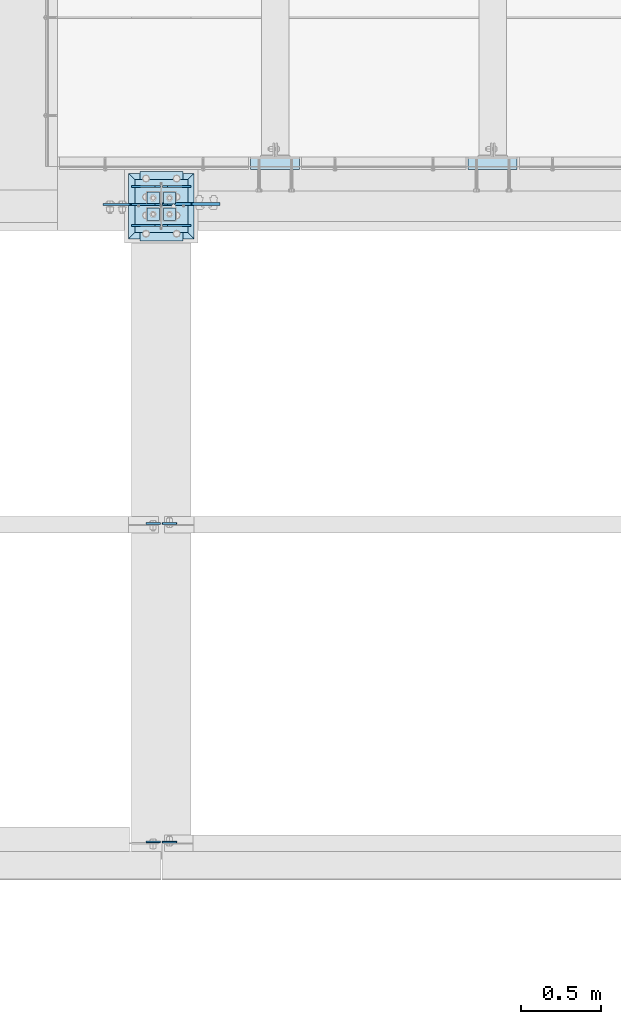
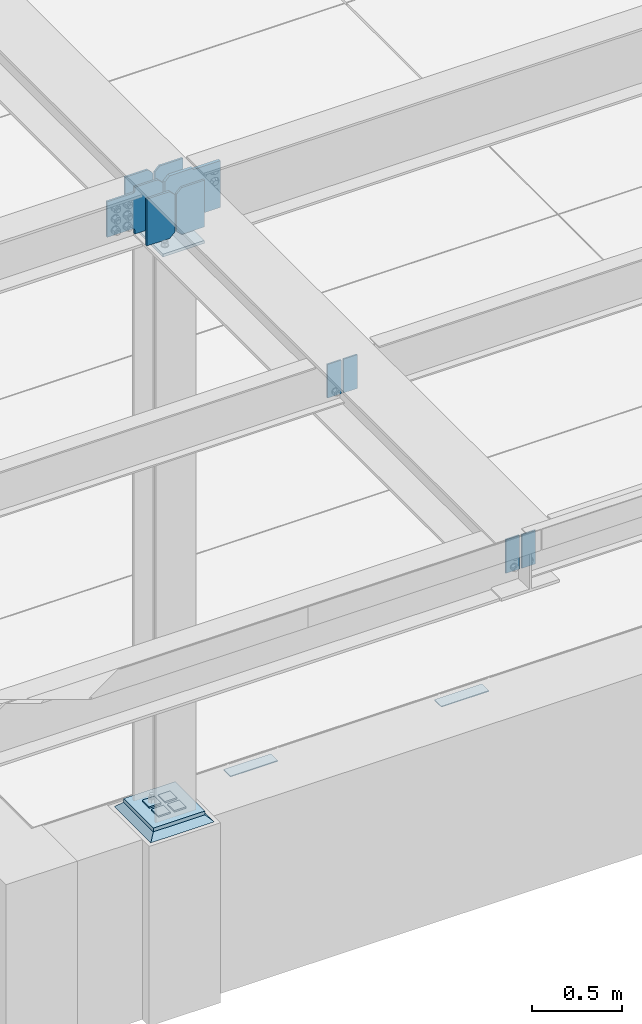
# One storey, part 3013 of 3843: 19 plates, 6 elements without a shape of their own.
"""IFC2X3 building model written with IfcOpenShell, lengths in millimetres."""

import ifcopenshell
import ifcopenshell.guid

model = None  # the IFC model being written
_history = None  # IfcOwnerHistory: only IFC2X3 demands one
_inside = {}  # id of a spatial element -> (the spatial element, [elements in it])
_under = {}  # id of a project, library or spatial element -> (it, [spatial elements below it])
_declared = {}  # id of a project -> (the project, [libraries it declares])
_typed = {}  # id of a type object -> (the type object, [elements of that type])
_made_of = {}  # id of a material, layer set ... -> (it, [elements and type objects made of it])


def new_model(schema):
    """Start an empty IFC model of exactly this schema.

    Asked for "IFC4X3", IfcOpenShell would pick the latest addendum, in which some entities
    have other attributes; the version numbers below select the first issue.
    IFC2X3 requires an IfcOwnerHistory on every rooted entity: one is made here for all.
    """
    global model, _history
    if schema == "IFC4X3":
        model = ifcopenshell.file(schema_version=(4, 3, 0, 0))
    else:
        model = ifcopenshell.file(schema=schema)
    _inside.clear()
    _under.clear()
    _declared.clear()
    _typed.clear()
    _made_of.clear()
    _history = None
    if model.schema == "IFC2X3":
        org = make("IfcOrganization", Name="unknown")
        user = make(
            "IfcPersonAndOrganization",
            ThePerson=make("IfcPerson", FamilyName="unknown"),
            TheOrganization=org,
        )
        app = make(
            "IfcApplication",
            ApplicationDeveloper=org,
            Version="unknown",
            ApplicationFullName="unknown",
            ApplicationIdentifier="unknown",
        )
        _history = make(
            "IfcOwnerHistory",
            OwningUser=user,
            OwningApplication=app,
            ChangeAction="ADDED",
            CreationDate=0,
        )
    return model


def make(cls, **values):
    """One entity of the class cls with the attributes given. An attribute that is None is left unset."""
    return model.create_entity(
        cls, **{name: value for name, value in values.items() if value is not None}
    )


def rooted(cls, **values):
    """An entity with a GlobalId (a new one), such as an element, a storey or a relation."""
    return make(cls, GlobalId=ifcopenshell.guid.new(), OwnerHistory=_history, **values)


def si_unit(unit_type, name, prefix=None):
    """IfcSIUnit, for example si_unit("LENGTHUNIT", "METRE", prefix="MILLI")."""
    return make("IfcSIUnit", UnitType=unit_type, Prefix=prefix, Name=name)


def assignment(units):
    """IfcUnitAssignment: the units of a project."""
    return None if units is None else make("IfcUnitAssignment", Units=units)


def point(xyz):
    """IfcCartesianPoint."""
    return None if xyz is None else make("IfcCartesianPoint", Coordinates=xyz)


def direction(xyz):
    """IfcDirection."""
    return None if xyz is None else make("IfcDirection", DirectionRatios=xyz)


def frame(location, z_axis=None, x_axis=None):
    """IfcAxis2Placement3D, a coordinate frame: its origin and axes. An axis left out is left unset."""
    return make(
        "IfcAxis2Placement3D",
        Location=point(location),
        Axis=direction(z_axis),
        RefDirection=direction(x_axis),
    )


def origin_with_axes():
    """The frame at (0, 0, 0) with the z axis (0, 0, 1) and the x axis (1, 0, 0) written out."""
    return frame((0.0, 0.0, 0.0), z_axis=(0.0, 0.0, 1.0), x_axis=(1.0, 0.0, 0.0))


def place(relative_to, where):
    """IfcLocalPlacement: puts the frame where relative to a parent placement (None: the world)."""
    return make(
        "IfcLocalPlacement", PlacementRelTo=relative_to, RelativePlacement=where
    )


def context(
    kind, dimensions, precision=None, world=None, true_north=None, identifier=None
):
    """IfcGeometricRepresentationContext, for example the 3D "Model" context."""
    return make(
        "IfcGeometricRepresentationContext",
        ContextIdentifier=identifier,
        ContextType=kind,
        CoordinateSpaceDimension=dimensions,
        Precision=precision,
        WorldCoordinateSystem=world,
        TrueNorth=true_north,
    )


def subcontext(parent, identifier, kind, view, scale=None):
    """IfcGeometricRepresentationSubContext, for example "Body" below "Model"."""
    return make(
        "IfcGeometricRepresentationSubContext",
        ContextIdentifier=identifier,
        ContextType=kind,
        ParentContext=parent,
        TargetScale=scale,
        TargetView=view,
    )


def project(units=None, contexts=None):
    """IfcProject with its units and contexts."""
    return rooted(
        "IfcProject",
        Name="project",
        RepresentationContexts=contexts,
        UnitsInContext=assignment(units),
    )


def spatial(cls, under=None, at=None, **own):
    """A site, building, storey or space (cls), placed at a placement, below another one or the project."""
    s = rooted(cls, ObjectPlacement=at, **own)
    if under is not None:
        _under.setdefault(under.id(), (under, []))[1].append(s)
    return s


def faces_of(points, faces, orient=None, outer=None):
    """IfcFace entities. A face is a list of loops; a loop is a list of indices into points, from 0.

    orient and outer hold one flag for each loop. By default every Orientation is true, the
    first loop of a face is its IfcFaceOuterBound and the others are IfcFaceBound.
    """
    made = []
    for i, loops in enumerate(faces):
        bounds = []
        for j, loop in enumerate(loops):
            is_outer = j == 0 if outer is None else outer[i][j]
            bounds.append(
                make(
                    "IfcFaceOuterBound" if is_outer else "IfcFaceBound",
                    Bound=make("IfcPolyLoop", Polygon=[points[k] for k in loop]),
                    Orientation=True if orient is None else orient[i][j],
                )
            )
        made.append(make("IfcFace", Bounds=bounds))
    return made


def faceted_brep(points, faces, orient=None, outer=None, voids=None):
    """IfcFacetedBrep: a solid bounded by flat faces; with voids (closed shells), ...WithVoids."""
    shared = [point(p) for p in points]
    hull = make("IfcClosedShell", CfsFaces=faces_of(shared, faces, orient, outer))
    if voids is None:
        return make("IfcFacetedBrep", Outer=hull)
    return make(
        "IfcFacetedBrepWithVoids",
        Outer=hull,
        Voids=[
            make(cls, CfsFaces=faces_of(shared, fs, o, b)) for cls, fs, o, b in voids
        ],
    )


def shape(context_of_items, identifier, shape_type, items):
    """IfcShapeRepresentation: the items that make up one representation, for example the "Body"."""
    return make(
        "IfcShapeRepresentation",
        ContextOfItems=context_of_items,
        RepresentationIdentifier=identifier,
        RepresentationType=shape_type,
        Items=items,
    )


def material(Name=None, Category=None):
    """IfcMaterial."""
    return make("IfcMaterial", Name=Name, Category=Category)


def made_of(thing, what):
    """Note that an element or type object is made of a material, layer set ...; save() writes the relation."""
    if what is not None:
        _made_of.setdefault(what.id(), (what, []))[1].append(thing)
    return thing


def type_object(cls, material=None, **own):
    """A type object (cls), such as IfcWallType, which elements share."""
    return made_of(rooted(cls, **own), material)


def element(
    cls,
    number,
    at=None,
    inside=None,
    cuts=None,
    type_object=None,
    material=None,
    context=None,
    identifier="Body",
    shape_type=None,
    held_by="IfcProductDefinitionShape",
    body=None,
    shapes=None,
    **own,
):
    """One element of the class cls, such as IfcWall. Its Tag is "e" and its number.

    at: its placement. inside: the storey or other place that contains it. cuts: it is an
    opening in that element (IfcRelVoidsElement). A single representation is given by context,
    identifier, shape_type and body (its items); several are given by shapes. held_by: the class
    of the entity that holds the representations. save() writes the other relations.
    """
    e = rooted(cls, Tag="e%d" % number, ObjectPlacement=at, **own)
    if body is not None:
        shapes = [shape(context, identifier, shape_type, body)]
    if shapes is not None:
        e.Representation = make(held_by, Representations=shapes)
    if inside is not None:
        _inside.setdefault(inside.id(), (inside, []))[1].append(e)
    if cuts is not None:
        rooted(
            "IfcRelVoidsElement", RelatingBuildingElement=cuts, RelatedOpeningElement=e
        )
    if type_object is not None:
        _typed.setdefault(type_object.id(), (type_object, []))[1].append(e)
    return made_of(e, material)


def aggregate(whole, parts):
    """IfcRelAggregates: a whole, such as a stair, and the parts it consists of."""
    return rooted("IfcRelAggregates", RelatingObject=whole, RelatedObjects=parts)


def save(model, path):
    """Write the relations noted so far, then the file.

    IfcRelAggregates (storeys below a building ...), IfcRelContainedInSpatialStructure (elements
    in a storey), IfcRelDefinesByType, IfcRelAssociatesMaterial and IfcRelDeclares: one each for
    every whole, place, type object, material and project.
    """
    for whole, parts in _under.values():
        aggregate(whole, parts)
    for where, things in _inside.values():
        rooted(
            "IfcRelContainedInSpatialStructure",
            RelatedElements=things,
            RelatingStructure=where,
        )
    for kind, things in _typed.values():
        rooted("IfcRelDefinesByType", RelatedObjects=things, RelatingType=kind)
    for what, things in _made_of.values():
        rooted("IfcRelAssociatesMaterial", RelatedObjects=things, RelatingMaterial=what)
    for by, libraries in _declared.values():
        rooted("IfcRelDeclares", RelatingContext=by, RelatedDefinitions=libraries)
    model.write(path)


model = new_model("IFC2X3")

# Units and contexts
model_context = context("Model", 3, precision=1e-05, world=origin_with_axes())
body_context = subcontext(model_context, "Body", "Model", "MODEL_VIEW")
ifc_project = project(units=[si_unit("LENGTHUNIT", "METRE", prefix="MILLI"), si_unit("AREAUNIT", "SQUARE_METRE"), si_unit("VOLUMEUNIT", "CUBIC_METRE"), si_unit("MASSUNIT", "GRAM", prefix="KILO"), si_unit("TIMEUNIT", "SECOND"), si_unit("PLANEANGLEUNIT", "RADIAN"), si_unit("SOLIDANGLEUNIT", "STERADIAN"), si_unit("THERMODYNAMICTEMPERATUREUNIT", "DEGREE_CELSIUS"), si_unit("LUMINOUSINTENSITYUNIT", "LUMEN")], contexts=[model_context])

# Site, building, storey
site_placement = place(None, origin_with_axes())
site = spatial("IfcSite", under=ifc_project, at=site_placement, CompositionType="ELEMENT")
building_placement = place(site_placement, origin_with_axes())
building = spatial("IfcBuilding", under=site, at=building_placement, Name="Undefined", CompositionType="ELEMENT")
storey_placement = place(building_placement, origin_with_axes())
storey = spatial("IfcBuildingStorey", under=building, at=storey_placement, Name="Undefined", CompositionType="ELEMENT", Elevation=0.0)

# Assembly, plate
assembly_1_placement = place(storey_placement, origin_with_axes())
assembly_1 = element("IfcElementAssembly", 1, at=assembly_1_placement, inside=storey, Name="EMBED PLATE", AssemblyPlace="NOTDEFINED", PredefinedType="RIGID_FRAME")
ifc_material_1 = material(Name="STEEL/A36")
plate_type_1 = type_object("IfcPlateType", PredefinedType="NOTDEFINED")
plate_1_placement = place(assembly_1_placement, frame((42618.025, 15303.5, 30400.625), z_axis=(1.0, 0.0, 0.0), x_axis=(0.0, -1.0, 0.0)))
plate_1 = element("IfcPlate", 2, at=plate_1_placement, type_object=plate_type_1, material=ifc_material_1, Name="PLATE", context=body_context, shape_type="Brep", body=[
    faceted_brep([(0.0, -3.17499999999927, 0.0), (0.0, -3.17499999999927, 304.800000000003), (0.0, 3.17499999999927, 304.800000000003), (0.0, 3.17499999999927, 0.0), (76.1999999999971, -3.17499999999927, 304.799999999996), (76.1999999999971, 3.17499999999927, 304.799999999996), (76.1999999999971, -3.17499999999927, 0.0), (76.1999999999971, 3.17499999999927, 0.0)], [[[0, 1, 2, 3]], [[1, 4, 5, 2]], [[4, 6, 7, 5]], [[6, 0, 3, 7]], [[5, 7, 3, 2]], [[6, 4, 1, 0]]]),
])
aggregate(assembly_1, [plate_1])

assembly_2_placement = place(storey_placement, origin_with_axes())
assembly_2 = element("IfcElementAssembly", 3, at=assembly_2_placement, inside=storey, Name="EMBED PLATE", AssemblyPlace="NOTDEFINED", PredefinedType="RIGID_FRAME")
plate_2_placement = place(assembly_2_placement, frame((43970.575, 15303.5000030518, 30400.625), z_axis=(1.0, 0.0, 0.0), x_axis=(0.0, -1.0, 0.0)))
plate_2 = element("IfcPlate", 4, at=plate_2_placement, type_object=plate_type_1, material=ifc_material_1, Name="PLATE", context=body_context, shape_type="Brep", body=[
    faceted_brep([(0.0, -3.17499999999927, 0.0), (0.0, -3.17499999999927, 304.800000000003), (0.0, 3.17499999999927, 304.800000000003), (0.0, 3.17499999999927, 0.0), (76.1999999999971, -3.17499999999927, 304.799999999996), (76.1999999999971, 3.17499999999927, 304.799999999996), (76.1999999999971, -3.17499999999927, 0.0), (76.1999999999971, 3.17499999999927, 0.0)], [[[0, 1, 2, 3]], [[1, 4, 5, 2]], [[4, 6, 7, 5]], [[6, 0, 3, 7]], [[5, 7, 3, 2]], [[6, 4, 1, 0]]]),
])
aggregate(assembly_2, [plate_2])

# Assembly, plates
assembly_3_placement = place(storey_placement, origin_with_axes())
assembly_3 = element("IfcElementAssembly", 5, at=assembly_3_placement, inside=storey, Name="BEAM", AssemblyPlace="NOTDEFINED", PredefinedType="RIGID_FRAME")
ifc_material_2 = material(Name="STEEL/A572-50")
plate_type_2 = type_object("IfcPlateType", PredefinedType="NOTDEFINED")
plate_3_placement = place(assembly_3_placement, frame((42068.75, 11044.2375, 34772.6), z_axis=(1.0, 0.0, 0.0), x_axis=(0.0, 0.0, -1.0)))
plate_3 = element("IfcPlate", 6, at=plate_3_placement, type_object=plate_type_2, material=ifc_material_2, Name="PLATE", context=body_context, shape_type="Brep", body=[
    faceted_brep([(0.0, -4.76249999999709, 0.0), (0.0, -4.76249999999709, 88.9000015258789), (0.0, 4.76249999999709, 88.9000015258789), (0.0, 4.76249999999709, 0.0), (228.600006102781, -4.7625000004191, 88.9000015257589), (228.600006102781, 4.76249999954598, 88.9000015257443), (228.600006103079, -4.7625000004482, 7.27595761418343e-12), (228.600006103079, 4.76249999954598, -7.27595761418343e-12)], [[[0, 1, 2, 3]], [[1, 4, 5, 2]], [[4, 6, 7, 5]], [[6, 0, 3, 7]], [[5, 7, 3, 2]], [[6, 4, 1, 0]]]),
])
plate_4_placement = place(assembly_3_placement, frame((42056.05, 11045.825, 34772.6), z_axis=(-1.0, 0.0, 0.0), x_axis=(0.0, 0.0, -1.0)))
plate_4 = element("IfcPlate", 7, at=plate_4_placement, type_object=plate_type_2, material=ifc_material_2, Name="PLATE", context=body_context, shape_type="Brep", body=[
    faceted_brep([(0.0, -4.76249999999709, 0.0), (0.0, -4.76249999999709, 88.9000015258789), (0.0, 4.76249999999709, 88.9000015258789), (0.0, 4.76249999999709, 0.0), (228.600006102781, -4.7625000004191, 88.9000015257589), (228.600006102781, 4.76249999954598, 88.9000015257443), (228.600006103079, -4.7625000004482, 7.27595761418343e-12), (228.600006103079, 4.76249999954598, -7.27595761418343e-12)], [[[0, 1, 2, 3]], [[1, 4, 5, 2]], [[4, 6, 7, 5]], [[6, 0, 3, 7]], [[5, 7, 3, 2]], [[6, 4, 1, 0]]]),
])
plate_5_placement = place(assembly_3_placement, frame((42068.75, 13025.4375, 34759.9), z_axis=(1.0, 0.0, 0.0), x_axis=(0.0, 0.0, -1.0)))
plate_5 = element("IfcPlate", 8, at=plate_5_placement, type_object=plate_type_2, material=ifc_material_2, Name="PLATE", context=body_context, shape_type="Brep", body=[
    faceted_brep([(0.0, -4.76249999999709, 0.0), (0.0, -4.76249999999709, 88.9000015258789), (0.0, 4.76249999999709, 88.9000015258789), (0.0, 4.76249999999709, 0.0), (228.600006102781, -4.7625000004191, 88.9000015257589), (228.600006102781, 4.76249999954598, 88.9000015257443), (228.600006103079, -4.7625000004482, 7.27595761418343e-12), (228.600006103079, 4.76249999954598, -7.27595761418343e-12)], [[[0, 1, 2, 3]], [[1, 4, 5, 2]], [[4, 6, 7, 5]], [[6, 0, 3, 7]], [[5, 7, 3, 2]], [[6, 4, 1, 0]]]),
])
plate_6_placement = place(assembly_3_placement, frame((42056.05, 13025.4375, 34759.9), z_axis=(-1.0, 0.0, 0.0), x_axis=(0.0, 0.0, -1.0)))
plate_6 = element("IfcPlate", 9, at=plate_6_placement, type_object=plate_type_2, material=ifc_material_2, Name="PLATE", context=body_context, shape_type="Brep", body=[
    faceted_brep([(0.0, -4.76249999999709, 0.0), (0.0, -4.76249999999709, 88.9000015258789), (0.0, 4.76249999999709, 88.9000015258789), (0.0, 4.76249999999709, 0.0), (228.600006102781, -4.7625000004191, 88.9000015257589), (228.600006102781, 4.76249999954598, 88.9000015257443), (228.600006103079, -4.7625000004482, 7.27595761418343e-12), (228.600006103079, 4.76249999954598, -7.27595761418343e-12)], [[[0, 1, 2, 3]], [[1, 4, 5, 2]], [[4, 6, 7, 5]], [[6, 0, 3, 7]], [[5, 7, 3, 2]], [[6, 4, 1, 0]]]),
])
plate_type_3 = type_object("IfcPlateType", PredefinedType="NOTDEFINED")
plate_7_placement = place(assembly_3_placement, frame((42248.1375, 14877.25625, 34790.0625), z_axis=(0.0, 0.0, -1.0), x_axis=(-1.0, 0.0, 0.0)))
plate_7 = element("IfcPlate", 10, at=plate_7_placement, type_object=plate_type_3, material=ifc_material_2, Name="PLATE", context=body_context, shape_type="Brep", body=[
    faceted_brep([(0.0, -6.3499999046162, 0.0), (0.0, -6.34999999999854, 317.5), (0.0, 6.34999999999854, 317.5), (7.27595761418343e-12, 6.3499999046162, 0.0), (147.637496948242, -6.35000000000036, 317.5), (147.637496948242, 6.35000000000036, 317.5), (179.387496948242, -6.35000000000036, 285.75), (179.387496948242, 6.35000000000036, 285.75), (179.387496948242, -6.35000000000036, 31.75), (179.387496948242, 6.35000000000036, 31.75), (147.637496948242, -6.35000000000036, 0.0), (147.637496948242, 6.35000000000036, 0.0)], [[[0, 1, 2, 3]], [[1, 4, 5, 2]], [[4, 6, 7, 5]], [[6, 8, 9, 7]], [[8, 10, 11, 9]], [[10, 0, 3, 11]], [[5, 7, 9, 11, 3, 2]], [[10, 8, 6, 4, 1, 0]]]),
])
plate_8_placement = place(assembly_3_placement, frame((41876.6625, 14877.25625, 34790.0625), z_axis=(0.0, 0.0, -1.0), x_axis=(1.0, 0.0, 0.0)))
plate_8 = element("IfcPlate", 11, at=plate_8_placement, type_object=plate_type_3, material=ifc_material_2, Name="PLATE", context=body_context, shape_type="Brep", body=[
    faceted_brep([(0.0, -6.3499999046162, 0.0), (0.0, -6.34999999999854, 317.5), (0.0, 6.34999999999854, 317.5), (7.27595761418343e-12, 6.3499999046162, 0.0), (147.637496948242, -6.35000000000036, 317.5), (147.637496948242, 6.35000000000036, 317.5), (179.387496948242, -6.35000000000036, 285.75), (179.387496948242, 6.35000000000036, 285.75), (179.387496948242, -6.35000000000036, 31.75), (179.387496948242, 6.35000000000036, 31.75), (147.637496948242, -6.35000000000036, 0.0), (147.637496948242, 6.35000000000036, 0.0)], [[[0, 1, 2, 3]], [[1, 4, 5, 2]], [[4, 6, 7, 5]], [[6, 8, 9, 7]], [[8, 10, 11, 9]], [[10, 0, 3, 11]], [[5, 7, 9, 11, 3, 2]], [[10, 8, 6, 4, 1, 0]]]),
])
plate_9_placement = place(assembly_3_placement, frame((42248.1375, 15120.14375, 34790.0625), z_axis=(0.0, 0.0, -1.0), x_axis=(-1.0, 0.0, 0.0)))
plate_9 = element("IfcPlate", 12, at=plate_9_placement, type_object=plate_type_3, material=ifc_material_2, Name="PLATE", context=body_context, shape_type="Brep", body=[
    faceted_brep([(0.0, -6.3499999046162, 0.0), (0.0, -6.34999999999854, 317.5), (0.0, 6.34999999999854, 317.5), (7.27595761418343e-12, 6.3499999046162, 0.0), (147.637496948242, -6.35000000000036, 317.5), (147.637496948242, 6.35000000000036, 317.5), (179.387496948242, -6.35000000000036, 285.75), (179.387496948242, 6.35000000000036, 285.75), (179.387496948242, -6.35000000000036, 31.75), (179.387496948242, 6.35000000000036, 31.75), (147.637496948242, -6.35000000000036, 0.0), (147.637496948242, 6.35000000000036, 0.0)], [[[0, 1, 2, 3]], [[1, 4, 5, 2]], [[4, 6, 7, 5]], [[6, 8, 9, 7]], [[8, 10, 11, 9]], [[10, 0, 3, 11]], [[5, 7, 9, 11, 3, 2]], [[10, 8, 6, 4, 1, 0]]]),
])
plate_10_placement = place(assembly_3_placement, frame((41876.6625, 15120.14375, 34790.0625), z_axis=(0.0, 0.0, -1.0), x_axis=(1.0, 0.0, 0.0)))
plate_10 = element("IfcPlate", 13, at=plate_10_placement, type_object=plate_type_3, material=ifc_material_2, Name="PLATE", context=body_context, shape_type="Brep", body=[
    faceted_brep([(0.0, -6.3499999046162, 0.0), (0.0, -6.34999999999854, 317.5), (0.0, 6.34999999999854, 317.5), (7.27595761418343e-12, 6.3499999046162, 0.0), (147.637496948242, -6.35000000000036, 317.5), (147.637496948242, 6.35000000000036, 317.5), (179.387496948242, -6.35000000000036, 285.75), (179.387496948242, 6.35000000000036, 285.75), (179.387496948242, -6.35000000000036, 31.75), (179.387496948242, 6.35000000000036, 31.75), (147.637496948242, -6.35000000000036, 0.0), (147.637496948242, 6.35000000000036, 0.0)], [[[0, 1, 2, 3]], [[1, 4, 5, 2]], [[4, 6, 7, 5]], [[6, 8, 9, 7]], [[8, 10, 11, 9]], [[10, 0, 3, 11]], [[5, 7, 9, 11, 3, 2]], [[10, 8, 6, 4, 1, 0]]]),
])

assembly_4_placement = place(storey_placement, origin_with_axes())
assembly_4 = element("IfcElementAssembly", 14, at=assembly_4_placement, inside=storey, Name="TEMPLATE", AssemblyPlace="NOTDEFINED", PredefinedType="RIGID_FRAME")
plate_type_4 = type_object("IfcPlateType", PredefinedType="NOTDEFINED")
plate_11_placement = place(assembly_4_placement, frame((42049.7, 14986.0, 30548.2625), z_axis=(-1.0, 0.0, 0.0), x_axis=(0.0, -1.0, 0.0)))
plate_11 = element("IfcPlate", 15, at=plate_11_placement, type_object=plate_type_4, material=ifc_material_2, Name="Washer Plate", context=body_context, shape_type="Brep", body=[
    faceted_brep([(0.0, -4.76249999999709, 0.0), (-3.49245965480804e-10, -4.76249999999709, 76.1999999999462), (-3.49245965480804e-10, 4.76249999999709, 76.1999999999462), (0.0, 4.76249999999709, 0.0), (76.1999893188477, -4.76249999999709, 76.1999969482422), (76.1999893188477, 4.76249999999709, 76.1999969482422), (76.2000000012922, -4.76250000000073, 7.27595761418343e-11), (76.2000000012922, 4.76250000000073, 7.27595761418343e-11)], [[[0, 1, 2, 3]], [[1, 4, 5, 2]], [[4, 6, 7, 5]], [[6, 0, 3, 7]], [[5, 7, 3, 2]], [[6, 4, 1, 0]]]),
])
plate_12_placement = place(assembly_4_placement, frame((42151.3, 14986.0, 30548.2625), z_axis=(-1.0, 0.0, 0.0), x_axis=(0.0, -1.0, 0.0)))
plate_12 = element("IfcPlate", 16, at=plate_12_placement, type_object=plate_type_4, material=ifc_material_2, Name="Washer Plate", context=body_context, shape_type="Brep", body=[
    faceted_brep([(0.0, -4.76249999999709, 0.0), (-3.49245965480804e-10, -4.76249999999709, 76.1999999999462), (-3.49245965480804e-10, 4.76249999999709, 76.1999999999462), (0.0, 4.76249999999709, 0.0), (76.1999893188477, -4.76249999999709, 76.1999969482422), (76.1999893188477, 4.76249999999709, 76.1999969482422), (76.2000000012922, -4.76250000000073, 7.27595761418343e-11), (76.2000000012922, 4.76250000000073, 7.27595761418343e-11)], [[[0, 1, 2, 3]], [[1, 4, 5, 2]], [[4, 6, 7, 5]], [[6, 0, 3, 7]], [[5, 7, 3, 2]], [[6, 4, 1, 0]]]),
])
plate_13_placement = place(assembly_4_placement, frame((42049.7, 15087.6, 30548.2625), z_axis=(-1.0, 0.0, 0.0), x_axis=(0.0, -1.0, 0.0)))
plate_13 = element("IfcPlate", 17, at=plate_13_placement, type_object=plate_type_4, material=ifc_material_2, Name="Washer Plate", context=body_context, shape_type="Brep", body=[
    faceted_brep([(0.0, -4.76249999999709, 0.0), (-3.49245965480804e-10, -4.76249999999709, 76.1999999999462), (-3.49245965480804e-10, 4.76249999999709, 76.1999999999462), (0.0, 4.76249999999709, 0.0), (76.1999893188477, -4.76249999999709, 76.1999969482422), (76.1999893188477, 4.76249999999709, 76.1999969482422), (76.2000000012922, -4.76250000000073, 7.27595761418343e-11), (76.2000000012922, 4.76250000000073, 7.27595761418343e-11)], [[[0, 1, 2, 3]], [[1, 4, 5, 2]], [[4, 6, 7, 5]], [[6, 0, 3, 7]], [[5, 7, 3, 2]], [[6, 4, 1, 0]]]),
])
plate_14_placement = place(assembly_4_placement, frame((42151.3, 15087.6, 30548.2625), z_axis=(-1.0, 0.0, 0.0), x_axis=(0.0, -1.0, 0.0)))
plate_14 = element("IfcPlate", 18, at=plate_14_placement, type_object=plate_type_4, material=ifc_material_2, Name="Washer Plate", context=body_context, shape_type="Brep", body=[
    faceted_brep([(0.0, -4.76249999999709, 0.0), (-3.49245965480804e-10, -4.76249999999709, 76.1999999999462), (-3.49245965480804e-10, 4.76249999999709, 76.1999999999462), (0.0, 4.76249999999709, 0.0), (76.1999893188477, -4.76249999999709, 76.1999969482422), (76.1999893188477, 4.76249999999709, 76.1999969482422), (76.2000000012922, -4.76250000000073, 7.27595761418343e-11), (76.2000000012922, 4.76250000000073, 7.27595761418343e-11)], [[[0, 1, 2, 3]], [[1, 4, 5, 2]], [[4, 6, 7, 5]], [[6, 0, 3, 7]], [[5, 7, 3, 2]], [[6, 4, 1, 0]]]),
])
aggregate(assembly_4, [plate_11, plate_12, plate_13, plate_14])

# Plate
plate_type_5 = type_object("IfcPlateType", PredefinedType="NOTDEFINED")
plate_15_placement = place(assembly_3_placement, frame((42056.05, 15009.8125000954, 34504.3125), z_axis=(-0.707106781186548, 0.0, 0.707106781186548), x_axis=(-0.707106781186548, 0.0, -0.707106781186548)))
plate_15 = element("IfcPlate", 19, at=plate_15_placement, type_object=plate_type_5, material=ifc_material_2, Name="PLATE", context=body_context, shape_type="Brep", body=[
    faceted_brep([(0.0, -6.3499999046162, 0.0), (-179.605117797444, -6.35000000000036, 179.605117797391), (-179.605117797444, 6.35000000000036, 179.605117797391), (7.27595761418343e-12, 6.3499999046162, 0.0), (-179.605117797451, -6.35000000000036, 224.506408690841), (-179.605117797451, 6.35000000000036, 224.506408690841), (-75.209648132186, -6.35000000000036, 328.90188598553), (-75.209648132186, 6.35000000000036, 328.90188598553), (-58.371662590318, -6.35000000000036, 312.063902931512), (-58.371662590318, 6.35000000000036, 312.063902931512), (-54.2514862690005, -6.35000000000036, 309.310889480477), (-54.2514862690005, 6.35000000000036, 309.310889480477), (-49.3914070874598, -6.35000000000036, 308.344159771879), (-49.3914070874598, 6.35000000000036, 308.344159771879), (-44.5313279333423, -6.35000000000036, 309.310889618328), (-44.5313279333423, 6.35000000000036, 309.310889618328), (-40.4111516901103, -6.35000000000036, 312.063903186225), (-40.4111516901103, 6.35000000000036, 312.063903186225), (76.332176208256, -6.35000000000036, 428.807220457964), (76.332176208256, 6.35000000000036, 428.807220457964), (246.957046508163, -6.35000000000036, 258.182373046277), (246.957046508163, 6.35000000000036, 258.182373046277), (130.213714368605, -6.35000000000036, 141.439026737824), (130.213714368605, 6.35000000000036, 141.439026737824), (127.460700791889, -6.35000000000036, 137.318850280621), (127.460700791889, 6.35000000000036, 137.318850280621), (126.493971090509, -6.35000000000036, 132.458770911258), (126.493971090509, 6.35000000000036, 132.458770911258), (127.460701086828, -6.35000000000036, 127.598691600562), (127.460701086828, 6.35000000000036, 127.598691600562), (130.213714913567, -6.35000000000036, 123.478515310422), (130.213714913567, 6.35000000000036, 123.478515310422), (149.296752929316, -6.35000000000036, 104.39547729468), (149.296752929316, 6.35000000000036, 104.39547729468), (44.9012806051323, -6.35000000000582, -1.45519152283669e-11), (44.9012806051323, 6.35000000000582, -1.45519152283669e-11)], [[[0, 1, 2, 3]], [[1, 4, 5, 2]], [[4, 6, 7, 5]], [[6, 8, 9, 7]], [[8, 10, 11, 9]], [[10, 12, 13, 11]], [[12, 14, 15, 13]], [[14, 16, 17, 15]], [[16, 18, 19, 17]], [[18, 20, 21, 19]], [[20, 22, 23, 21]], [[22, 24, 25, 23]], [[24, 26, 27, 25]], [[26, 28, 29, 27]], [[28, 30, 31, 29]], [[30, 32, 33, 31]], [[32, 34, 35, 33]], [[34, 0, 3, 35]], [[5, 7, 9, 11, 13, 15, 17, 19, 21, 23, 25, 27, 29, 31, 33, 35, 3, 2]], [[34, 32, 30, 28, 26, 24, 22, 20, 18, 16, 14, 12, 10, 8, 6, 4, 1, 0]]]),
])

# Assembly, plate
assembly_5_placement = place(storey_placement, origin_with_axes())
assembly_5 = element("IfcElementAssembly", 20, at=assembly_5_placement, inside=storey, Name="COLUMN", AssemblyPlace="NOTDEFINED", PredefinedType="RIGID_FRAME")
plate_type_6 = type_object("IfcPlateType", PredefinedType="NOTDEFINED")
plate_16_placement = place(assembly_5_placement, frame((41897.3, 15163.8, 30530.8), z_axis=(1.0, 0.0, 0.0), x_axis=(0.0, -1.0, 0.0)))
plate_16 = element("IfcPlate", 21, at=plate_16_placement, type_object=plate_type_6, material=ifc_material_2, Name="PLATE", context=body_context, shape_type="Brep", body=[
    faceted_brep([(0.0, -12.6999999999971, 0.0), (0.0, -12.6999999999825, 330.199999999997), (-1.45519152283669e-11, 12.699999999968, 330.199999999997), (0.0, 12.6999999999971, 0.0), (330.200012207031, -12.7000000000007, 330.200012207031), (330.200012207031, 12.7000000000007, 330.200012207031), (330.200012207031, -12.7000000000007, 0.0), (330.200012207031, 12.7000000000007, 0.0)], [[[0, 1, 2, 3]], [[1, 4, 5, 2]], [[4, 6, 7, 5]], [[6, 0, 3, 7]], [[5, 7, 3, 2]], [[6, 4, 1, 0]]]),
])

# Plate
plate_type_7 = type_object("IfcPlateType", PredefinedType="NOTDEFINED")
plate_17_placement = place(assembly_3_placement, frame((42068.75, 15012.9875003815, 34504.3125), z_axis=(0.707106781186548, 0.0, 0.707106781186548), x_axis=(0.707106781186548, 0.0, -0.707106781186548)))
plate_17 = element("IfcPlate", 22, at=plate_17_placement, type_object=plate_type_7, material=ifc_material_2, Name="PLATE", context=body_context, shape_type="Brep", body=[
    faceted_brep([(0.0, -9.52500000000146, 0.0), (-179.605122420516, -9.52499999999964, 179.605122420522), (-179.605122420516, 9.52499999999964, 179.605122420522), (0.0, 9.52500000000146, 0.0), (-179.605122420516, -9.52499999999964, 224.506403025654), (-179.605122420516, 9.52499999999964, 224.506403025654), (-75.2096450135841, -9.52499999999964, 328.901880432582), (-75.2096450135841, 9.52499999999964, 328.901880432582), (-71.8420489007704, -9.52499999999964, 325.534284319772), (-71.8420489007704, 9.52499999999964, 325.534284319772), (-69.7819606666935, -9.52499999999964, 324.157777369539), (-69.7819606666935, 9.52499999999964, 324.157777369539), (-67.3519209076849, -9.52499999999964, 323.674412408247), (-67.3519209076849, 9.52499999999964, 323.674412408247), (-64.9218811486617, -9.52499999999964, 324.157777369539), (-64.9218811486617, 9.52499999999964, 324.157777369539), (-62.8617929145885, -9.52499999999964, 325.53428431978), (-62.8617929145885, 9.52499999999964, 325.53428431978), (58.3716647866777, -9.52499999999964, 446.767742021046), (58.3716647866777, 9.52499999999964, 446.767742021046), (282.878067812325, -9.52499999999964, 222.261338995399), (282.878067812325, 9.52499999999964, 222.261338995399), (157.154482117966, -9.52499999999964, 96.5377533010396), (157.154482117966, 9.52499999999964, 96.5377533010396), (149.296758012067, -9.52499999999964, 104.395477406928), (149.296758012067, 9.52499999999964, 104.395477406928), (44.9012806055835, -9.52499999999418, 4.65661287307739e-10), (44.9012806055835, 9.52499999999418, 4.65661287307739e-10)], [[[0, 1, 2, 3]], [[1, 4, 5, 2]], [[4, 6, 7, 5]], [[6, 8, 9, 7]], [[8, 10, 11, 9]], [[10, 12, 13, 11]], [[12, 14, 15, 13]], [[14, 16, 17, 15]], [[16, 18, 19, 17]], [[18, 20, 21, 19]], [[20, 22, 23, 21]], [[22, 24, 25, 23]], [[24, 26, 27, 25]], [[26, 0, 3, 27]], [[5, 7, 9, 11, 13, 15, 17, 19, 21, 23, 25, 27, 3, 2]], [[26, 24, 22, 20, 18, 16, 14, 12, 10, 8, 6, 4, 1, 0]]]),
])

aggregate(assembly_3, [plate_17, plate_15, plate_7, plate_8, plate_9, plate_10, plate_3, plate_4, plate_5, plate_6])

plate_type_8 = type_object("IfcPlateType", PredefinedType="NOTDEFINED")
plate_18_placement = place(assembly_5_placement, frame((42195.75, 14782.8, 34442.4), z_axis=(0.0, 1.0, 0.0), x_axis=(-1.0, 0.0, 0.0)))
plate_18 = element("IfcPlate", 23, at=plate_18_placement, type_object=plate_type_8, material=ifc_material_2, Name="PLATE", context=body_context, shape_type="Brep", body=[
    faceted_brep([(0.0, -9.52500000000146, 0.0), (0.0, -9.52500000000146, 431.799987792969), (0.0, 9.52500000000146, 431.799987792969), (0.0, 9.52500000000146, 0.0), (266.700012207031, -9.52500000000146, 431.799987792969), (266.700012207031, 9.52500000000146, 431.799987792969), (266.700012207031, -9.52500000000146, 0.0), (266.700012207031, 9.52500000000146, 0.0)], [[[0, 1, 2, 3]], [[1, 4, 5, 2]], [[4, 6, 7, 5]], [[6, 0, 3, 7]], [[5, 7, 3, 2]], [[6, 4, 1, 0]]]),
])

aggregate(assembly_5, [plate_18, plate_16])

# Assembly, plate
assembly_6_placement = place(storey_placement, origin_with_axes())
assembly_6 = element("IfcElementAssembly", 24, at=assembly_6_placement, inside=storey, Name="GROUT", AssemblyPlace="NOTDEFINED", PredefinedType="REINFORCEMENT_UNIT")
ifc_material_3 = material(Name="CONCRETE/Concrete_Undefined")
plate_type_9 = type_object("IfcPlateType", PredefinedType="NOTDEFINED")
plate_19_placement = place(assembly_6_placement, frame((41859.2, 15201.9, 30499.05), z_axis=(1.0, 0.0, 0.0), x_axis=(0.0, -1.0, 0.0)))
plate_19 = element("IfcPlate", 25, at=plate_19_placement, type_object=plate_type_9, material=ifc_material_3, Name="GROUT", context=body_context, shape_type="Brep", body=[
    faceted_brep([(38.1000000006916, -19.0499999997883, 368.299999999334), (0.0, 19.0499999999993, 406.399993896484), (0.0, 19.0500000000029, 0.0), (38.1000000006916, -19.0499999999811, 38.1000000006607), (368.299999999343, -19.049999999821, 38.1000000006607), (406.399993896484, 19.0499999999993, 0.0), (406.399993896484, 19.0499999999993, 406.399993896484), (368.299999999343, -19.0499999999811, 368.299999999334)], [[[0, 1, 2, 3]], [[4, 5, 6, 7]], [[4, 7, 0, 3]], [[5, 4, 3, 2]], [[6, 5, 2, 1]], [[7, 6, 1, 0]]]),
])
aggregate(assembly_6, [plate_19])

save(model, "model.ifc")
